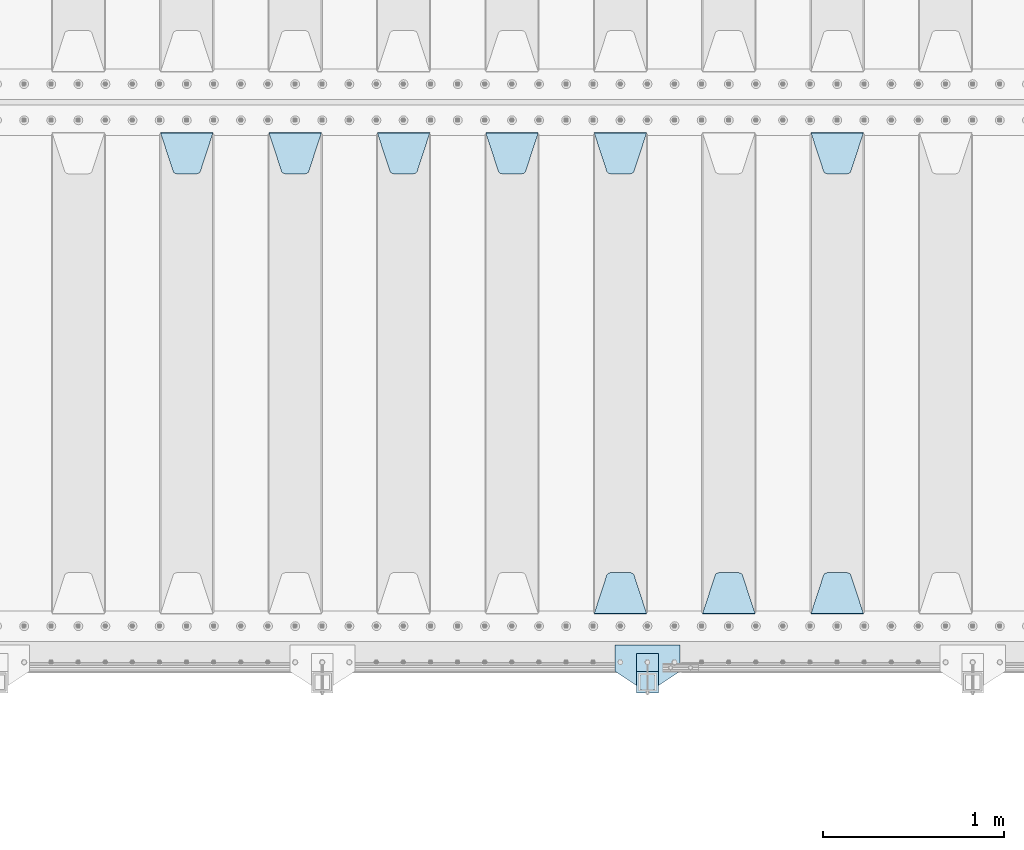
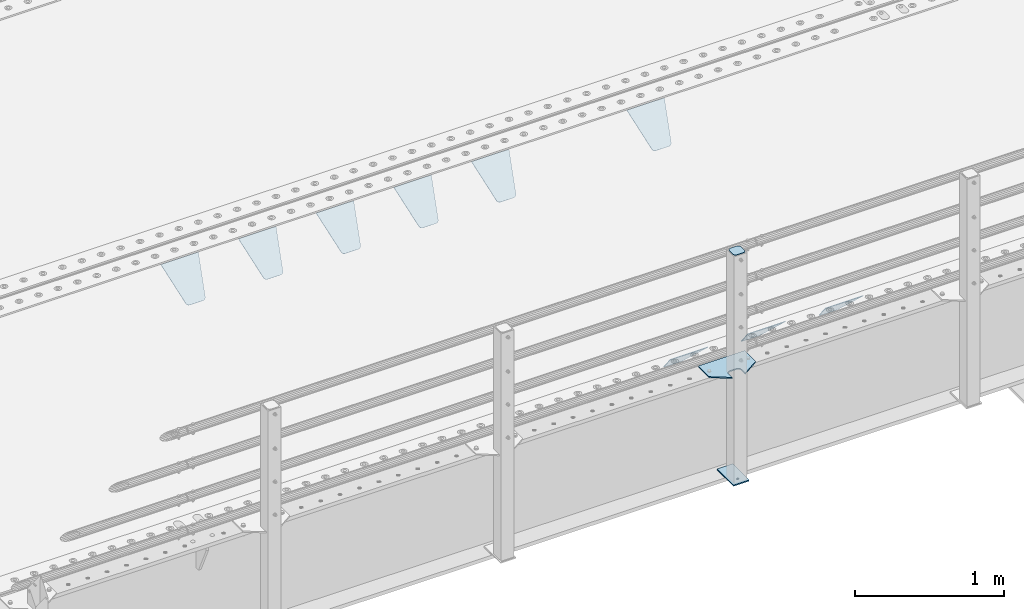
# One storey, part 209 of 257: 13 plates.
"""IFC2X3 building model written with IfcOpenShell, lengths in millimetres."""

from ifc_helpers import new_model, si_unit, frame, origin_with_axes, place, context, subcontext, project, spatial, faceted_brep, material, type_object, element, save


model = new_model("IFC2X3")

# Units and contexts
model_context = context("Model", 3, precision=1e-05, world=origin_with_axes())
body_context = subcontext(model_context, "Body", "Model", "MODEL_VIEW")
ifc_project = project(units=[si_unit("LENGTHUNIT", "METRE", prefix="MILLI"), si_unit("AREAUNIT", "SQUARE_METRE"), si_unit("VOLUMEUNIT", "CUBIC_METRE"), si_unit("MASSUNIT", "GRAM", prefix="KILO"), si_unit("TIMEUNIT", "SECOND"), si_unit("PLANEANGLEUNIT", "RADIAN"), si_unit("SOLIDANGLEUNIT", "STERADIAN"), si_unit("THERMODYNAMICTEMPERATUREUNIT", "DEGREE_CELSIUS"), si_unit("LUMINOUSINTENSITYUNIT", "LUMEN")], contexts=[model_context])

# Site, building, storey
site_placement = place(None, origin_with_axes())
site = spatial("IfcSite", under=ifc_project, at=site_placement, CompositionType="ELEMENT")
building_placement = place(site_placement, origin_with_axes())
building = spatial("IfcBuilding", under=site, at=building_placement, Name="Standard", CompositionType="ELEMENT")
storey_placement = place(building_placement, origin_with_axes())
storey = spatial("IfcBuildingStorey", under=building, at=storey_placement, Name="Undefined", CompositionType="ELEMENT", Elevation=0.0)

# Plates
ifc_material_1 = material(Name="STEEL/S355N")
plate_type_1 = type_object("IfcPlateType", PredefinedType="NOTDEFINED")
plate_1_placement = place(storey_placement, frame((52905.0, 2831.76776695594, -1.767766952965), z_axis=(0.0, -0.707106781186548, -0.707106781186547), x_axis=(1.0, 0.0, 0.0)))
element("IfcPlate", 1, at=plate_1_placement, inside=storey, type_object=plate_type_1, material=ifc_material_1, context=body_context, shape_type="Brep", body=[
    faceted_brep([(0.0, -2.5, 0.0), (69.345504679477, -2.50000000000091, 300.17173142483), (69.345504679477, 2.5, 300.171731424831), (0.0, 2.5, 0.0), (70.927406119954, -2.50000000000091, 304.8974424154), (70.927406119954, 2.5, 304.8974424154), (73.3818627772271, -2.50000000000091, 309.234538108527), (73.3818627772271, 2.49999999999909, 309.234538108527), (76.6187032999587, -2.5, 313.023683126103), (76.6187032999587, 2.5, 313.023683126103), (80.5190132705029, -2.5, 316.125672595372), (80.5190132705029, 2.5, 316.125672595371), (84.9395038596849, -2.5, 318.426546230476), (84.9395038596849, 2.5, 318.426546230477), (89.7177759439219, -2.5, 319.841774983275), (89.7177759439219, 2.5, 319.841774983275), (94.6782862926484, -2.5, 320.319366455079), (94.6782862926484, 2.5, 320.319366455079), (195.321713707352, -2.5, 320.319366455079), (195.321713707352, 2.5, 320.319366455079), (200.282224056078, -2.5, 319.841774983275), (200.282224056078, 2.49999999999909, 319.841774983275), (205.060496140315, -2.5, 318.426546230476), (205.060496140315, 2.49999999999909, 318.426546230475), (209.480986729497, -2.5, 316.125672595371), (209.480986729497, 2.5, 316.125672595371), (213.381296700041, -2.50000000000091, 313.023683126102), (213.381296700041, 2.5, 313.023683126103), (216.618137222766, -2.50000000000091, 309.234538108527), (216.618137222766, 2.5, 309.234538108527), (219.072593880039, -2.5, 304.897442415399), (219.072593880039, 2.5, 304.897442415399), (220.654495320523, -2.50000000000091, 300.17173142483), (220.654495320523, 2.5, 300.171731424831), (290.0, -2.50000000000091, 0.0), (290.0, 2.5, 9.09494701772928e-13)], [[[0, 1, 2, 3]], [[1, 4, 5, 2]], [[4, 6, 7, 5]], [[6, 8, 9, 7]], [[8, 10, 11, 9]], [[10, 12, 13, 11]], [[12, 14, 15, 13]], [[14, 16, 17, 15]], [[16, 18, 19, 17]], [[18, 20, 21, 19]], [[20, 22, 23, 21]], [[22, 24, 25, 23]], [[24, 26, 27, 25]], [[26, 28, 29, 27]], [[28, 30, 31, 29]], [[30, 32, 33, 31]], [[32, 34, 35, 33]], [[34, 0, 3, 35]], [[5, 7, 9, 11, 13, 15, 17, 19, 21, 23, 25, 27, 29, 31, 33, 35, 3, 2]], [[34, 32, 30, 28, 26, 24, 22, 20, 18, 16, 14, 12, 10, 8, 6, 4, 1, 0]]]),
])
plate_2_placement = place(storey_placement, frame((53195.0, 168.232233047035, -1.76776695296758), z_axis=(0.0, 0.707106781186547, -0.707106781186548), x_axis=(-1.0, 0.0, 0.0)))
element("IfcPlate", 2, at=plate_2_placement, inside=storey, type_object=plate_type_1, material=ifc_material_1, context=body_context, shape_type="Brep", body=[
    faceted_brep([(0.0, -2.5, 0.0), (69.345504679477, -2.50000000000091, 300.17173142483), (69.345504679477, 2.5, 300.171731424831), (0.0, 2.5, 0.0), (70.927406119954, -2.50000000000091, 304.8974424154), (70.927406119954, 2.5, 304.8974424154), (73.3818627772271, -2.50000000000091, 309.234538108527), (73.3818627772271, 2.49999999999909, 309.234538108527), (76.6187032999587, -2.5, 313.023683126103), (76.6187032999587, 2.5, 313.023683126103), (80.5190132705029, -2.5, 316.125672595372), (80.5190132705029, 2.5, 316.125672595371), (84.9395038596849, -2.5, 318.426546230476), (84.9395038596849, 2.5, 318.426546230477), (89.7177759439219, -2.5, 319.841774983275), (89.7177759439219, 2.5, 319.841774983275), (94.6782862926484, -2.5, 320.319366455079), (94.6782862926484, 2.5, 320.319366455079), (195.321713707352, -2.5, 320.319366455079), (195.321713707352, 2.5, 320.319366455079), (200.282224056078, -2.5, 319.841774983275), (200.282224056078, 2.49999999999909, 319.841774983275), (205.060496140315, -2.5, 318.426546230476), (205.060496140315, 2.49999999999909, 318.426546230475), (209.480986729497, -2.5, 316.125672595371), (209.480986729497, 2.5, 316.125672595371), (213.381296700041, -2.50000000000091, 313.023683126102), (213.381296700041, 2.5, 313.023683126103), (216.618137222766, -2.50000000000091, 309.234538108527), (216.618137222766, 2.5, 309.234538108527), (219.072593880039, -2.5, 304.897442415399), (219.072593880039, 2.5, 304.897442415399), (220.654495320523, -2.50000000000091, 300.17173142483), (220.654495320523, 2.5, 300.171731424831), (290.0, -2.50000000000091, 0.0), (290.0, 2.5, 9.09494701772928e-13)], [[[0, 1, 2, 3]], [[1, 4, 5, 2]], [[4, 6, 7, 5]], [[6, 8, 9, 7]], [[8, 10, 11, 9]], [[10, 12, 13, 11]], [[12, 14, 15, 13]], [[14, 16, 17, 15]], [[16, 18, 19, 17]], [[18, 20, 21, 19]], [[20, 22, 23, 21]], [[22, 24, 25, 23]], [[24, 26, 27, 25]], [[26, 28, 29, 27]], [[28, 30, 31, 29]], [[30, 32, 33, 31]], [[32, 34, 35, 33]], [[34, 0, 3, 35]], [[5, 7, 9, 11, 13, 15, 17, 19, 21, 23, 25, 27, 29, 31, 33, 35, 3, 2]], [[34, 32, 30, 28, 26, 24, 22, 20, 18, 16, 14, 12, 10, 8, 6, 4, 1, 0]]]),
])
plate_3_placement = place(storey_placement, frame((52595.0, 168.232233047034, -1.76776695296758), z_axis=(0.0, 0.707106781186547, -0.707106781186548), x_axis=(-1.0, 0.0, 0.0)))
element("IfcPlate", 3, at=plate_3_placement, inside=storey, type_object=plate_type_1, material=ifc_material_1, context=body_context, shape_type="Brep", body=[
    faceted_brep([(0.0, -2.5, 0.0), (69.345504679477, -2.50000000000091, 300.17173142483), (69.345504679477, 2.5, 300.171731424831), (0.0, 2.5, 0.0), (70.927406119954, -2.50000000000091, 304.8974424154), (70.927406119954, 2.5, 304.8974424154), (73.3818627772271, -2.50000000000091, 309.234538108527), (73.3818627772271, 2.49999999999909, 309.234538108527), (76.6187032999587, -2.5, 313.023683126103), (76.6187032999587, 2.5, 313.023683126103), (80.5190132705029, -2.5, 316.125672595372), (80.5190132705029, 2.5, 316.125672595371), (84.9395038596849, -2.5, 318.426546230476), (84.9395038596849, 2.5, 318.426546230477), (89.7177759439219, -2.5, 319.841774983275), (89.7177759439219, 2.5, 319.841774983275), (94.6782862926484, -2.5, 320.319366455079), (94.6782862926484, 2.5, 320.319366455079), (195.321713707352, -2.5, 320.319366455079), (195.321713707352, 2.5, 320.319366455079), (200.282224056078, -2.5, 319.841774983275), (200.282224056078, 2.49999999999909, 319.841774983275), (205.060496140315, -2.5, 318.426546230476), (205.060496140315, 2.49999999999909, 318.426546230475), (209.480986729497, -2.5, 316.125672595371), (209.480986729497, 2.5, 316.125672595371), (213.381296700041, -2.50000000000091, 313.023683126102), (213.381296700041, 2.5, 313.023683126103), (216.618137222766, -2.50000000000091, 309.234538108527), (216.618137222766, 2.5, 309.234538108527), (219.072593880039, -2.5, 304.897442415399), (219.072593880039, 2.5, 304.897442415399), (220.654495320523, -2.50000000000091, 300.17173142483), (220.654495320523, 2.5, 300.171731424831), (290.0, -2.50000000000091, 0.0), (290.0, 2.5, 9.09494701772928e-13)], [[[0, 1, 2, 3]], [[1, 4, 5, 2]], [[4, 6, 7, 5]], [[6, 8, 9, 7]], [[8, 10, 11, 9]], [[10, 12, 13, 11]], [[12, 14, 15, 13]], [[14, 16, 17, 15]], [[16, 18, 19, 17]], [[18, 20, 21, 19]], [[20, 22, 23, 21]], [[22, 24, 25, 23]], [[24, 26, 27, 25]], [[26, 28, 29, 27]], [[28, 30, 31, 29]], [[30, 32, 33, 31]], [[32, 34, 35, 33]], [[34, 0, 3, 35]], [[5, 7, 9, 11, 13, 15, 17, 19, 21, 23, 25, 27, 29, 31, 33, 35, 3, 2]], [[34, 32, 30, 28, 26, 24, 22, 20, 18, 16, 14, 12, 10, 8, 6, 4, 1, 0]]]),
])
plate_4_placement = place(storey_placement, frame((51705.0, 2831.76776695594, -1.767766952965), z_axis=(0.0, -0.707106781186548, -0.707106781186547), x_axis=(1.0, 0.0, 0.0)))
element("IfcPlate", 4, at=plate_4_placement, inside=storey, type_object=plate_type_1, material=ifc_material_1, context=body_context, shape_type="Brep", body=[
    faceted_brep([(0.0, -2.5, 0.0), (69.345504679477, -2.50000000000091, 300.17173142483), (69.345504679477, 2.5, 300.171731424831), (0.0, 2.5, 0.0), (70.927406119954, -2.50000000000091, 304.8974424154), (70.927406119954, 2.5, 304.8974424154), (73.3818627772271, -2.50000000000091, 309.234538108527), (73.3818627772271, 2.49999999999909, 309.234538108527), (76.6187032999587, -2.5, 313.023683126103), (76.6187032999587, 2.5, 313.023683126103), (80.5190132705029, -2.5, 316.125672595372), (80.5190132705029, 2.5, 316.125672595371), (84.9395038596849, -2.5, 318.426546230476), (84.9395038596849, 2.5, 318.426546230477), (89.7177759439219, -2.5, 319.841774983275), (89.7177759439219, 2.5, 319.841774983275), (94.6782862926484, -2.5, 320.319366455079), (94.6782862926484, 2.5, 320.319366455079), (195.321713707352, -2.5, 320.319366455079), (195.321713707352, 2.5, 320.319366455079), (200.282224056078, -2.5, 319.841774983275), (200.282224056078, 2.49999999999909, 319.841774983275), (205.060496140315, -2.5, 318.426546230476), (205.060496140315, 2.49999999999909, 318.426546230475), (209.480986729497, -2.5, 316.125672595371), (209.480986729497, 2.5, 316.125672595371), (213.381296700041, -2.50000000000091, 313.023683126102), (213.381296700041, 2.5, 313.023683126103), (216.618137222766, -2.50000000000091, 309.234538108527), (216.618137222766, 2.5, 309.234538108527), (219.072593880039, -2.5, 304.897442415399), (219.072593880039, 2.5, 304.897442415399), (220.654495320523, -2.50000000000091, 300.17173142483), (220.654495320523, 2.5, 300.171731424831), (290.0, -2.50000000000091, 0.0), (290.0, 2.5, 9.09494701772928e-13)], [[[0, 1, 2, 3]], [[1, 4, 5, 2]], [[4, 6, 7, 5]], [[6, 8, 9, 7]], [[8, 10, 11, 9]], [[10, 12, 13, 11]], [[12, 14, 15, 13]], [[14, 16, 17, 15]], [[16, 18, 19, 17]], [[18, 20, 21, 19]], [[20, 22, 23, 21]], [[22, 24, 25, 23]], [[24, 26, 27, 25]], [[26, 28, 29, 27]], [[28, 30, 31, 29]], [[30, 32, 33, 31]], [[32, 34, 35, 33]], [[34, 0, 3, 35]], [[5, 7, 9, 11, 13, 15, 17, 19, 21, 23, 25, 27, 29, 31, 33, 35, 3, 2]], [[34, 32, 30, 28, 26, 24, 22, 20, 18, 16, 14, 12, 10, 8, 6, 4, 1, 0]]]),
])
plate_5_placement = place(storey_placement, frame((51995.0, 168.232233047034, -1.76776695296758), z_axis=(0.0, 0.707106781186547, -0.707106781186548), x_axis=(-1.0, 0.0, 0.0)))
element("IfcPlate", 5, at=plate_5_placement, inside=storey, type_object=plate_type_1, material=ifc_material_1, context=body_context, shape_type="Brep", body=[
    faceted_brep([(0.0, -2.5, 0.0), (69.345504679477, -2.50000000000091, 300.17173142483), (69.345504679477, 2.5, 300.171731424831), (0.0, 2.5, 0.0), (70.927406119954, -2.50000000000091, 304.8974424154), (70.927406119954, 2.5, 304.8974424154), (73.3818627772271, -2.50000000000091, 309.234538108527), (73.3818627772271, 2.49999999999909, 309.234538108527), (76.6187032999587, -2.5, 313.023683126103), (76.6187032999587, 2.5, 313.023683126103), (80.5190132705029, -2.5, 316.125672595372), (80.5190132705029, 2.5, 316.125672595371), (84.9395038596849, -2.5, 318.426546230476), (84.9395038596849, 2.5, 318.426546230477), (89.7177759439219, -2.5, 319.841774983275), (89.7177759439219, 2.5, 319.841774983275), (94.6782862926484, -2.5, 320.319366455079), (94.6782862926484, 2.5, 320.319366455079), (195.321713707352, -2.5, 320.319366455079), (195.321713707352, 2.5, 320.319366455079), (200.282224056078, -2.5, 319.841774983275), (200.282224056078, 2.49999999999909, 319.841774983275), (205.060496140315, -2.5, 318.426546230476), (205.060496140315, 2.49999999999909, 318.426546230475), (209.480986729497, -2.5, 316.125672595371), (209.480986729497, 2.5, 316.125672595371), (213.381296700041, -2.50000000000091, 313.023683126102), (213.381296700041, 2.5, 313.023683126103), (216.618137222766, -2.50000000000091, 309.234538108527), (216.618137222766, 2.5, 309.234538108527), (219.072593880039, -2.5, 304.897442415399), (219.072593880039, 2.5, 304.897442415399), (220.654495320523, -2.50000000000091, 300.17173142483), (220.654495320523, 2.5, 300.171731424831), (290.0, -2.50000000000091, 0.0), (290.0, 2.5, 9.09494701772928e-13)], [[[0, 1, 2, 3]], [[1, 4, 5, 2]], [[4, 6, 7, 5]], [[6, 8, 9, 7]], [[8, 10, 11, 9]], [[10, 12, 13, 11]], [[12, 14, 15, 13]], [[14, 16, 17, 15]], [[16, 18, 19, 17]], [[18, 20, 21, 19]], [[20, 22, 23, 21]], [[22, 24, 25, 23]], [[24, 26, 27, 25]], [[26, 28, 29, 27]], [[28, 30, 31, 29]], [[30, 32, 33, 31]], [[32, 34, 35, 33]], [[34, 0, 3, 35]], [[5, 7, 9, 11, 13, 15, 17, 19, 21, 23, 25, 27, 29, 31, 33, 35, 3, 2]], [[34, 32, 30, 28, 26, 24, 22, 20, 18, 16, 14, 12, 10, 8, 6, 4, 1, 0]]]),
])
plate_6_placement = place(storey_placement, frame((51105.0, 2831.76776695594, -1.767766952965), z_axis=(0.0, -0.707106781186548, -0.707106781186547), x_axis=(1.0, 0.0, 0.0)))
element("IfcPlate", 6, at=plate_6_placement, inside=storey, type_object=plate_type_1, material=ifc_material_1, context=body_context, shape_type="Brep", body=[
    faceted_brep([(0.0, -2.5, 0.0), (69.345504679477, -2.50000000000091, 300.17173142483), (69.345504679477, 2.5, 300.171731424831), (0.0, 2.5, 0.0), (70.927406119954, -2.50000000000091, 304.8974424154), (70.927406119954, 2.5, 304.8974424154), (73.3818627772271, -2.50000000000091, 309.234538108527), (73.3818627772271, 2.49999999999909, 309.234538108527), (76.6187032999587, -2.5, 313.023683126103), (76.6187032999587, 2.5, 313.023683126103), (80.5190132705029, -2.5, 316.125672595372), (80.5190132705029, 2.5, 316.125672595371), (84.9395038596849, -2.5, 318.426546230476), (84.9395038596849, 2.5, 318.426546230477), (89.7177759439219, -2.5, 319.841774983275), (89.7177759439219, 2.5, 319.841774983275), (94.6782862926484, -2.5, 320.319366455079), (94.6782862926484, 2.5, 320.319366455079), (195.321713707352, -2.5, 320.319366455079), (195.321713707352, 2.5, 320.319366455079), (200.282224056078, -2.5, 319.841774983275), (200.282224056078, 2.49999999999909, 319.841774983275), (205.060496140315, -2.5, 318.426546230476), (205.060496140315, 2.49999999999909, 318.426546230475), (209.480986729497, -2.5, 316.125672595371), (209.480986729497, 2.5, 316.125672595371), (213.381296700041, -2.50000000000091, 313.023683126102), (213.381296700041, 2.5, 313.023683126103), (216.618137222766, -2.50000000000091, 309.234538108527), (216.618137222766, 2.5, 309.234538108527), (219.072593880039, -2.5, 304.897442415399), (219.072593880039, 2.5, 304.897442415399), (220.654495320523, -2.50000000000091, 300.17173142483), (220.654495320523, 2.5, 300.171731424831), (290.0, -2.50000000000091, 0.0), (290.0, 2.5, 9.09494701772928e-13)], [[[0, 1, 2, 3]], [[1, 4, 5, 2]], [[4, 6, 7, 5]], [[6, 8, 9, 7]], [[8, 10, 11, 9]], [[10, 12, 13, 11]], [[12, 14, 15, 13]], [[14, 16, 17, 15]], [[16, 18, 19, 17]], [[18, 20, 21, 19]], [[20, 22, 23, 21]], [[22, 24, 25, 23]], [[24, 26, 27, 25]], [[26, 28, 29, 27]], [[28, 30, 31, 29]], [[30, 32, 33, 31]], [[32, 34, 35, 33]], [[34, 0, 3, 35]], [[5, 7, 9, 11, 13, 15, 17, 19, 21, 23, 25, 27, 29, 31, 33, 35, 3, 2]], [[34, 32, 30, 28, 26, 24, 22, 20, 18, 16, 14, 12, 10, 8, 6, 4, 1, 0]]]),
])
plate_7_placement = place(storey_placement, frame((50505.0, 2831.76776695594, -1.767766952965), z_axis=(0.0, -0.707106781186548, -0.707106781186547), x_axis=(1.0, 0.0, 0.0)))
element("IfcPlate", 7, at=plate_7_placement, inside=storey, type_object=plate_type_1, material=ifc_material_1, context=body_context, shape_type="Brep", body=[
    faceted_brep([(0.0, -2.5, 0.0), (69.345504679477, -2.50000000000091, 300.17173142483), (69.345504679477, 2.5, 300.171731424831), (0.0, 2.5, 0.0), (70.927406119954, -2.50000000000091, 304.8974424154), (70.927406119954, 2.5, 304.8974424154), (73.3818627772271, -2.50000000000091, 309.234538108527), (73.3818627772271, 2.49999999999909, 309.234538108527), (76.6187032999587, -2.5, 313.023683126103), (76.6187032999587, 2.5, 313.023683126103), (80.5190132705029, -2.5, 316.125672595372), (80.5190132705029, 2.5, 316.125672595371), (84.9395038596849, -2.5, 318.426546230476), (84.9395038596849, 2.5, 318.426546230477), (89.7177759439219, -2.5, 319.841774983275), (89.7177759439219, 2.5, 319.841774983275), (94.6782862926484, -2.5, 320.319366455079), (94.6782862926484, 2.5, 320.319366455079), (195.321713707352, -2.5, 320.319366455079), (195.321713707352, 2.5, 320.319366455079), (200.282224056078, -2.5, 319.841774983275), (200.282224056078, 2.49999999999909, 319.841774983275), (205.060496140315, -2.5, 318.426546230476), (205.060496140315, 2.49999999999909, 318.426546230475), (209.480986729497, -2.5, 316.125672595371), (209.480986729497, 2.5, 316.125672595371), (213.381296700041, -2.50000000000091, 313.023683126102), (213.381296700041, 2.5, 313.023683126103), (216.618137222766, -2.50000000000091, 309.234538108527), (216.618137222766, 2.5, 309.234538108527), (219.072593880039, -2.5, 304.897442415399), (219.072593880039, 2.5, 304.897442415399), (220.654495320523, -2.50000000000091, 300.17173142483), (220.654495320523, 2.5, 300.171731424831), (290.0, -2.50000000000091, 0.0), (290.0, 2.5, 9.09494701772928e-13)], [[[0, 1, 2, 3]], [[1, 4, 5, 2]], [[4, 6, 7, 5]], [[6, 8, 9, 7]], [[8, 10, 11, 9]], [[10, 12, 13, 11]], [[12, 14, 15, 13]], [[14, 16, 17, 15]], [[16, 18, 19, 17]], [[18, 20, 21, 19]], [[20, 22, 23, 21]], [[22, 24, 25, 23]], [[24, 26, 27, 25]], [[26, 28, 29, 27]], [[28, 30, 31, 29]], [[30, 32, 33, 31]], [[32, 34, 35, 33]], [[34, 0, 3, 35]], [[5, 7, 9, 11, 13, 15, 17, 19, 21, 23, 25, 27, 29, 31, 33, 35, 3, 2]], [[34, 32, 30, 28, 26, 24, 22, 20, 18, 16, 14, 12, 10, 8, 6, 4, 1, 0]]]),
])
plate_8_placement = place(storey_placement, frame((49905.0, 2831.76776695594, -1.767766952965), z_axis=(0.0, -0.707106781186548, -0.707106781186547), x_axis=(1.0, 0.0, 0.0)))
element("IfcPlate", 8, at=plate_8_placement, inside=storey, type_object=plate_type_1, material=ifc_material_1, context=body_context, shape_type="Brep", body=[
    faceted_brep([(0.0, -2.5, 0.0), (69.345504679477, -2.50000000000091, 300.17173142483), (69.345504679477, 2.5, 300.171731424831), (0.0, 2.5, 0.0), (70.927406119954, -2.50000000000091, 304.8974424154), (70.927406119954, 2.5, 304.8974424154), (73.3818627772271, -2.50000000000091, 309.234538108527), (73.3818627772271, 2.49999999999909, 309.234538108527), (76.6187032999587, -2.5, 313.023683126103), (76.6187032999587, 2.5, 313.023683126103), (80.5190132705029, -2.5, 316.125672595372), (80.5190132705029, 2.5, 316.125672595371), (84.9395038596849, -2.5, 318.426546230476), (84.9395038596849, 2.5, 318.426546230477), (89.7177759439219, -2.5, 319.841774983275), (89.7177759439219, 2.5, 319.841774983275), (94.6782862926484, -2.5, 320.319366455079), (94.6782862926484, 2.5, 320.319366455079), (195.321713707352, -2.5, 320.319366455079), (195.321713707352, 2.5, 320.319366455079), (200.282224056078, -2.5, 319.841774983275), (200.282224056078, 2.49999999999909, 319.841774983275), (205.060496140315, -2.5, 318.426546230476), (205.060496140315, 2.49999999999909, 318.426546230475), (209.480986729497, -2.5, 316.125672595371), (209.480986729497, 2.5, 316.125672595371), (213.381296700041, -2.50000000000091, 313.023683126102), (213.381296700041, 2.5, 313.023683126103), (216.618137222766, -2.50000000000091, 309.234538108527), (216.618137222766, 2.5, 309.234538108527), (219.072593880039, -2.5, 304.897442415399), (219.072593880039, 2.5, 304.897442415399), (220.654495320523, -2.50000000000091, 300.17173142483), (220.654495320523, 2.5, 300.171731424831), (290.0, -2.50000000000091, 0.0), (290.0, 2.5, 9.09494701772928e-13)], [[[0, 1, 2, 3]], [[1, 4, 5, 2]], [[4, 6, 7, 5]], [[6, 8, 9, 7]], [[8, 10, 11, 9]], [[10, 12, 13, 11]], [[12, 14, 15, 13]], [[14, 16, 17, 15]], [[16, 18, 19, 17]], [[18, 20, 21, 19]], [[20, 22, 23, 21]], [[22, 24, 25, 23]], [[24, 26, 27, 25]], [[26, 28, 29, 27]], [[28, 30, 31, 29]], [[30, 32, 33, 31]], [[32, 34, 35, 33]], [[34, 0, 3, 35]], [[5, 7, 9, 11, 13, 15, 17, 19, 21, 23, 25, 27, 29, 31, 33, 35, 3, 2]], [[34, 32, 30, 28, 26, 24, 22, 20, 18, 16, 14, 12, 10, 8, 6, 4, 1, 0]]]),
])
plate_9_placement = place(storey_placement, frame((49305.0, 2831.76776695594, -1.767766952965), z_axis=(0.0, -0.707106781186548, -0.707106781186547), x_axis=(1.0, 0.0, 0.0)))
element("IfcPlate", 9, at=plate_9_placement, inside=storey, type_object=plate_type_1, material=ifc_material_1, context=body_context, shape_type="Brep", body=[
    faceted_brep([(0.0, -2.5, 0.0), (69.345504679477, -2.50000000000091, 300.17173142483), (69.345504679477, 2.5, 300.171731424831), (0.0, 2.5, 0.0), (70.927406119954, -2.50000000000091, 304.8974424154), (70.927406119954, 2.5, 304.8974424154), (73.3818627772271, -2.50000000000091, 309.234538108527), (73.3818627772271, 2.49999999999909, 309.234538108527), (76.6187032999587, -2.5, 313.023683126103), (76.6187032999587, 2.5, 313.023683126103), (80.5190132705029, -2.5, 316.125672595372), (80.5190132705029, 2.5, 316.125672595371), (84.9395038596849, -2.5, 318.426546230476), (84.9395038596849, 2.5, 318.426546230477), (89.7177759439219, -2.5, 319.841774983275), (89.7177759439219, 2.5, 319.841774983275), (94.6782862926484, -2.5, 320.319366455079), (94.6782862926484, 2.5, 320.319366455079), (195.321713707352, -2.5, 320.319366455079), (195.321713707352, 2.5, 320.319366455079), (200.282224056078, -2.5, 319.841774983275), (200.282224056078, 2.49999999999909, 319.841774983275), (205.060496140315, -2.5, 318.426546230476), (205.060496140315, 2.49999999999909, 318.426546230475), (209.480986729497, -2.5, 316.125672595371), (209.480986729497, 2.5, 316.125672595371), (213.381296700041, -2.50000000000091, 313.023683126102), (213.381296700041, 2.5, 313.023683126103), (216.618137222766, -2.50000000000091, 309.234538108527), (216.618137222766, 2.5, 309.234538108527), (219.072593880039, -2.5, 304.897442415399), (219.072593880039, 2.5, 304.897442415399), (220.654495320523, -2.50000000000091, 300.17173142483), (220.654495320523, 2.5, 300.171731424831), (290.0, -2.50000000000091, 0.0), (290.0, 2.5, 9.09494701772928e-13)], [[[0, 1, 2, 3]], [[1, 4, 5, 2]], [[4, 6, 7, 5]], [[6, 8, 9, 7]], [[8, 10, 11, 9]], [[10, 12, 13, 11]], [[12, 14, 15, 13]], [[14, 16, 17, 15]], [[16, 18, 19, 17]], [[18, 20, 21, 19]], [[20, 22, 23, 21]], [[22, 24, 25, 23]], [[24, 26, 27, 25]], [[26, 28, 29, 27]], [[28, 30, 31, 29]], [[30, 32, 33, 31]], [[32, 34, 35, 33]], [[34, 0, 3, 35]], [[5, 7, 9, 11, 13, 15, 17, 19, 21, 23, 25, 27, 29, 31, 33, 35, 3, 2]], [[34, 32, 30, 28, 26, 24, 22, 20, 18, 16, 14, 12, 10, 8, 6, 4, 1, 0]]]),
])
ifc_material_2 = material(Name="STEEL/S355J2")
plate_type_2 = type_object("IfcPlateType", PredefinedType="NOTDEFINED")
plate_10_placement = place(storey_placement, frame((52180.0, -4.99999999999636, 5.00000000004911), z_axis=(0.0, -1.0, 0.0), x_axis=(-1.0, 0.0, 0.0)))
element("IfcPlate", 10, at=plate_10_placement, inside=storey, type_object=plate_type_2, material=ifc_material_2, context=body_context, shape_type="Brep", body=[
    faceted_brep([(0.0, -5.0, 0.0), (2.31396552408114e-06, -5.0, 145.0), (2.31396552408114e-06, 5.0, 145.0), (0.0, 5.0, 0.0), (130.0, -5.0, 230.0), (130.0, 5.0, 230.0), (130.0, -5.0, 180.0), (130.0, 5.0, 180.0), (130.48036798992, -5.0, 175.122741949597), (130.48036798992, 5.0, 175.122741949597), (131.903011687216, -5.0, 170.432914190873), (131.903011687216, 5.0, 170.432914190873), (134.213259692435, -5.0, 166.11074417451), (134.213259692435, 5.0, 166.11074417451), (137.322330470335, -5.0, 162.322330470337), (137.322330470335, 5.0, 162.322330470337), (141.110744174512, -5.0, 159.213259692437), (141.110744174512, 5.0, 159.213259692437), (145.432914190875, -5.0, 156.903011687218), (145.432914190875, 5.0, 156.903011687218), (150.122741949599, -5.0, 155.48036798992), (150.122741949599, 5.0, 155.48036798992), (155.0, -5.0, 155.0), (155.0, 5.0, 155.0), (205.0, -5.0, 155.0), (205.0, 5.0, 155.0), (209.877258050401, -5.0, 155.48036798992), (209.877258050401, 5.0, 155.48036798992), (214.567085809125, -5.0, 156.903011687218), (214.567085809125, 5.0, 156.903011687218), (218.889255825488, -5.0, 159.213259692437), (218.889255825488, 5.0, 159.213259692437), (222.677669529665, -5.0, 162.322330470337), (222.677669529665, 5.0, 162.322330470337), (225.786740307565, -5.0, 166.11074417451), (225.786740307565, 5.0, 166.11074417451), (228.096988312784, -5.0, 170.432914190873), (228.096988312784, 5.0, 170.432914190873), (229.51963201008, -5.0, 175.122741949597), (229.51963201008, 5.0, 175.122741949597), (230.0, -5.0, 180.0), (230.0, 5.0, 180.0), (230.0, -5.0, 230.0), (230.0, 5.0, 230.0), (360.0, -5.0, 145.0), (360.0, 5.0, 145.0), (360.0, -5.0, -7.27595761418343e-12), (360.0, 5.0, -7.27595761418343e-12)], [[[0, 1, 2, 3]], [[1, 4, 5, 2]], [[4, 6, 7, 5]], [[6, 8, 9, 7]], [[8, 10, 11, 9]], [[10, 12, 13, 11]], [[12, 14, 15, 13]], [[14, 16, 17, 15]], [[16, 18, 19, 17]], [[18, 20, 21, 19]], [[20, 22, 23, 21]], [[22, 24, 25, 23]], [[24, 26, 27, 25]], [[26, 28, 29, 27]], [[28, 30, 31, 29]], [[30, 32, 33, 31]], [[32, 34, 35, 33]], [[34, 36, 37, 35]], [[36, 38, 39, 37]], [[38, 40, 41, 39]], [[40, 42, 43, 41]], [[42, 44, 45, 43]], [[44, 46, 47, 45]], [[46, 0, 3, 47]], [[5, 7, 9, 11, 13, 15, 17, 19, 21, 23, 25, 27, 29, 31, 33, 35, 37, 39, 41, 43, 45, 47, 3, 2]], [[46, 44, 42, 40, 38, 36, 34, 32, 30, 28, 26, 24, 22, 20, 18, 16, 14, 12, 10, 8, 6, 4, 1, 0]]]),
])
plate_type_3 = type_object("IfcPlateType", PredefinedType="NOTDEFINED")
plate_11_placement = place(storey_placement, frame((52059.9999999999, -50.0000000002074, -850.000000000002), z_axis=(0.0, -1.0, 0.0), x_axis=(-1.0, 0.0, 0.0)))
element("IfcPlate", 11, at=plate_11_placement, inside=storey, type_object=plate_type_3, material=ifc_material_2, context=body_context, shape_type="Brep", body=[
    faceted_brep([(53.6360389691836, -5.0, 176.363961030469), (53.6360389691836, 5.0, 176.363961030469), (59.9999999998618, 5.0, 178.999999999791), (59.9999999998618, -5.0, 178.999999999791), (66.3639610305399, 5.0, 176.363961030469), (66.3639610305399, -5.0, 176.363961030469), (68.9999999998618, 5.0, 169.999999999791), (68.9999999998618, -5.0, 169.999999999791), (66.3639610305399, 5.0, 163.636038969113), (66.3639610305399, -5.0, 163.636038969113), (59.9999999998618, 5.0, 160.999999999791), (59.9999999998618, -5.0, 160.999999999791), (53.6360389691836, 5.0, 163.636038969113), (53.6360389691836, -5.0, 163.636038969113), (50.9999999998618, 5.0, 169.999999999791), (50.9999999998618, -5.0, 169.999999999791), (120.0, -5.0, 0.0), (120.0, -5.0, 220.0), (0.0, -5.0, 220.0), (0.0, -5.0, 0.0), (0.0, 5.0, 0.0), (120.0, 5.0, 0.0), (120.0, 5.0, 220.0), (0.0, 5.0, 220.0)], [[[0, 1, 2, 3]], [[3, 2, 4, 5]], [[5, 4, 6, 7]], [[7, 6, 8, 9]], [[9, 8, 10, 11]], [[11, 10, 12, 13]], [[13, 12, 14, 15]], [[15, 14, 1, 0]], [[16, 17, 18, 19], [11, 13, 15, 0, 3, 5, 7, 9]], [[16, 19, 20, 21]], [[17, 16, 21, 22]], [[18, 17, 22, 23]], [[19, 18, 23, 20]], [[22, 21, 20, 23], [2, 1, 14, 12, 10, 8, 6, 4]]]),
])
plate_type_4 = type_object("IfcPlateType", PredefinedType="NOTDEFINED")
plate_12_placement = place(storey_placement, frame((51955.9999999999, -166.000000000207, 1012.50000000001), z_axis=(0.0, -1.0, 0.0), x_axis=(1.0, 0.0, 0.0)))
element("IfcPlate", 12, at=plate_12_placement, inside=storey, type_object=plate_type_4, material=ifc_material_2, context=body_context, shape_type="Brep", body=[
    faceted_brep([(0.0, -2.5, 19.0), (0.0, -2.5, 69.0), (0.0, 2.5, 69.0), (0.0, 2.5, 19.0), (0.476369668547704, -2.5, 73.2278977451697), (0.476369668547704, 2.5, 73.2278977451697), (1.88159150985302, -2.5, 77.2437910432327), (1.88159150985302, 2.5, 77.2437910432327), (4.14520183311106, -2.5, 80.8463062353167), (4.14520183311106, 2.5, 80.8463062353167), (7.15369376468152, -2.5, 83.8547981668926), (7.15369376468152, 2.5, 83.8547981668926), (10.7562089567655, -2.5, 86.1184084901452), (10.7562089567655, 2.5, 86.1184084901452), (14.7721022548285, -2.5, 87.5236303314541), (14.7721022548285, 2.5, 87.5236303314541), (19.0, -2.5, 88.0), (19.0, 2.5, 88.0), (69.0, -2.5, 88.0), (69.0, 2.5, 88.0), (73.2278977451715, -2.5, 87.5236303314541), (73.2278977451715, 2.5, 87.5236303314541), (77.2437910432345, -2.5, 86.1184084901452), (77.2437910432345, 2.5, 86.1184084901452), (80.8463062353185, -2.5, 83.8547981668926), (80.8463062353185, 2.5, 83.8547981668926), (83.8547981668889, -2.5, 80.8463062353167), (83.8547981668889, 2.5, 80.8463062353167), (86.118408490147, -2.5, 77.2437910432327), (86.118408490147, 2.5, 77.2437910432327), (87.5236303314523, -2.5, 73.2278977451697), (87.5236303314523, 2.5, 73.2278977451697), (88.0, -2.5, 69.0), (88.0, 2.5, 69.0), (88.0, -2.5, 19.0), (88.0, 2.5, 19.0), (87.5236303314523, -2.5, 14.7721022548303), (87.5236303314523, 2.5, 14.7721022548303), (86.118408490147, -2.5, 10.7562089567673), (86.118408490147, 2.5, 10.7562089567673), (83.8547981668889, -2.5, 7.15369376468334), (83.8547981668889, 2.5, 7.15369376468334), (80.8463062353185, -2.5, 4.14520183310742), (80.8463062353185, 2.5, 4.14520183310742), (77.2437910432345, -2.5, 1.88159150985484), (77.2437910432345, 2.5, 1.88159150985484), (73.2278977451715, -2.5, 0.476369668545885), (73.2278977451715, 2.5, 0.476369668545885), (69.0, -2.5, 0.0), (69.0, 2.5, 0.0), (19.0, -2.5, 0.0), (19.0, 2.5, 0.0), (14.7721022548285, -2.5, 0.476369668545885), (14.7721022548285, 2.5, 0.476369668545885), (10.7562089567655, -2.5, 1.88159150985484), (10.7562089567655, 2.5, 1.88159150985484), (7.15369376468152, -2.5, 4.14520183310742), (7.15369376468152, 2.5, 4.14520183310742), (4.14520183311106, -2.5, 7.15369376468334), (4.14520183311106, 2.5, 7.15369376468334), (1.88159150985302, -2.5, 10.7562089567673), (1.88159150985302, 2.5, 10.7562089567673), (0.476369668547704, -2.5, 14.7721022548303), (0.476369668547704, 2.5, 14.7721022548303)], [[[0, 1, 2, 3]], [[1, 4, 5, 2]], [[4, 6, 7, 5]], [[6, 8, 9, 7]], [[8, 10, 11, 9]], [[10, 12, 13, 11]], [[12, 14, 15, 13]], [[14, 16, 17, 15]], [[16, 18, 19, 17]], [[18, 20, 21, 19]], [[20, 22, 23, 21]], [[22, 24, 25, 23]], [[24, 26, 27, 25]], [[26, 28, 29, 27]], [[28, 30, 31, 29]], [[30, 32, 33, 31]], [[32, 34, 35, 33]], [[34, 36, 37, 35]], [[36, 38, 39, 37]], [[38, 40, 41, 39]], [[40, 42, 43, 41]], [[42, 44, 45, 43]], [[44, 46, 47, 45]], [[46, 48, 49, 47]], [[48, 50, 51, 49]], [[50, 52, 53, 51]], [[52, 54, 55, 53]], [[54, 56, 57, 55]], [[56, 58, 59, 57]], [[58, 60, 61, 59]], [[60, 62, 63, 61]], [[62, 0, 3, 63]], [[5, 7, 9, 11, 13, 15, 17, 19, 21, 23, 25, 27, 29, 31, 33, 35, 37, 39, 41, 43, 45, 47, 49, 51, 53, 55, 57, 59, 61, 63, 3, 2]], [[62, 60, 58, 56, 54, 52, 50, 48, 46, 44, 42, 40, 38, 36, 34, 32, 30, 28, 26, 24, 22, 20, 18, 16, 14, 12, 10, 8, 6, 4, 1, 0]]]),
])
plate_type_5 = type_object("IfcPlateType", PredefinedType="NOTDEFINED")
plate_13_placement = place(storey_placement, frame((52059.9999999999, -50.0000000002074, -857.500000000002), z_axis=(0.0, -1.0, 0.0), x_axis=(-1.0, 0.0, 0.0)))
element("IfcPlate", 13, at=plate_13_placement, inside=storey, type_object=plate_type_5, material=ifc_material_2, context=body_context, shape_type="Brep", body=[
    faceted_brep([(0.0, -2.5, 0.0), (0.0, -2.5, 100.0), (0.0, 2.5, 100.0), (0.0, 2.5, 0.0), (120.0, -2.5, 100.0), (120.0, 2.5, 100.0), (120.0, -2.5, 0.0), (120.0, 2.5, 0.0)], [[[0, 1, 2, 3]], [[1, 4, 5, 2]], [[4, 6, 7, 5]], [[6, 0, 3, 7]], [[5, 7, 3, 2]], [[6, 4, 1, 0]]]),
])

save(model, "model.ifc")
